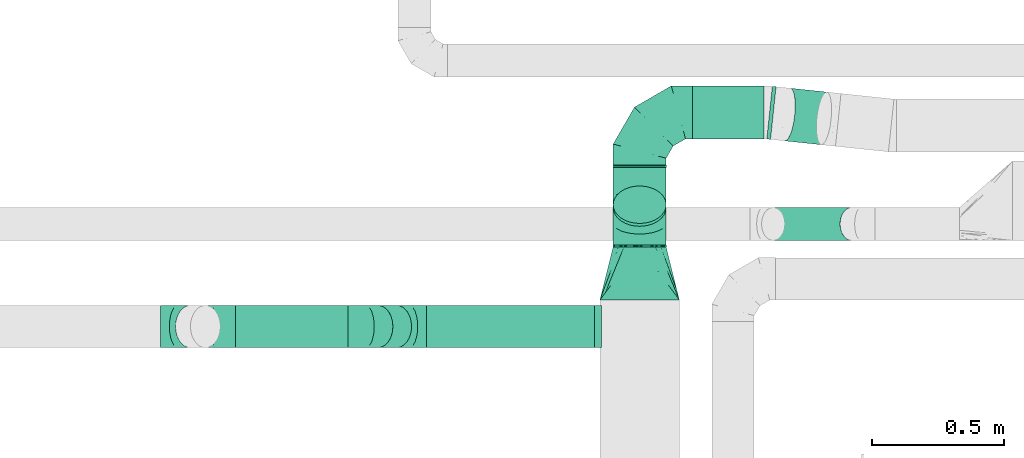
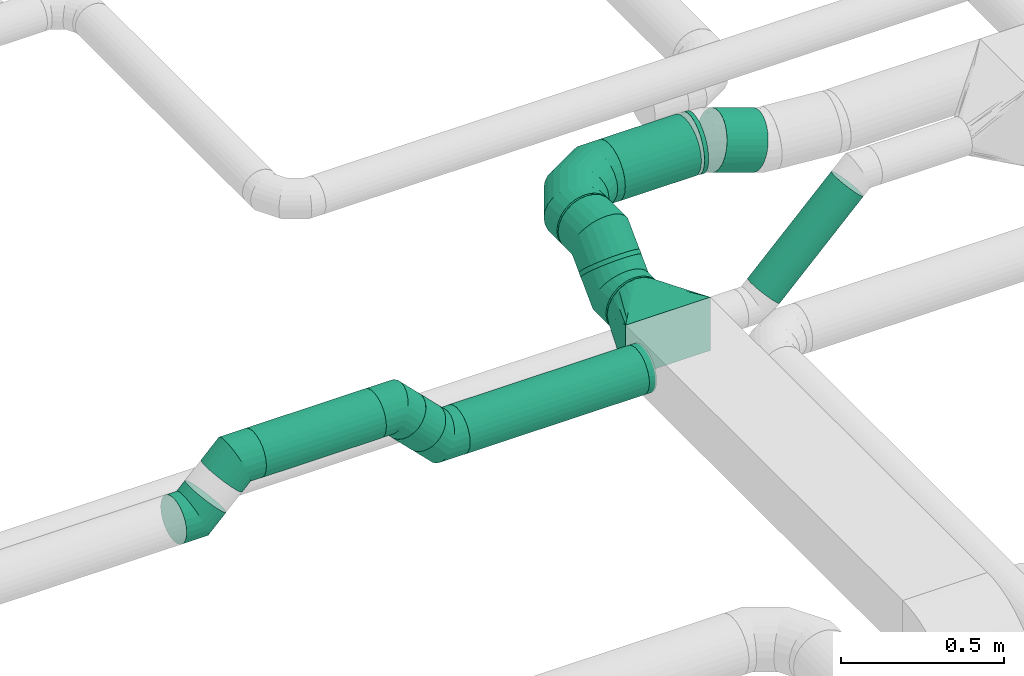
# One storey, part 10 of 60: 10 flow segments, 9 flow fittings.
"""IFC2X3 building model written with IfcOpenShell, lengths in millimetres."""

from ifc_helpers import new_model, entity, si_unit, converted_unit, derived_unit, direction, frame, origin, origin_2d_with_axis, place, context, subcontext, project, spatial, circle, extrude, faceted_brep, source, transform, mapped, material, type_object, type_shapes, element, save


model = new_model("IFC2X3")

# Units and contexts
model_context = context("Model", 3, precision=0.01, world=origin(), true_north=direction((6.12303176911189e-17, 1.0)))
body_context = subcontext(model_context, "Body", "Model", "MODEL_VIEW")
ifc_project = project(units=[si_unit("LENGTHUNIT", "METRE", prefix="MILLI"), si_unit("AREAUNIT", "SQUARE_METRE"), si_unit("VOLUMEUNIT", "CUBIC_METRE"), converted_unit("PLANEANGLEUNIT", "DEGREE", entity("IfcRatioMeasure", 0.0174532925199433), si_unit("PLANEANGLEUNIT", "RADIAN"), dimensions=[0, 0, 0, 0, 0, 0, 0]), si_unit("MASSUNIT", "GRAM", prefix="KILO"), derived_unit("MASSDENSITYUNIT", [(si_unit("MASSUNIT", "GRAM", prefix="KILO"), 1), (si_unit("LENGTHUNIT", "METRE"), -3)]), derived_unit("MOMENTOFINERTIAUNIT", [(si_unit("LENGTHUNIT", "METRE"), 4)]), si_unit("TIMEUNIT", "SECOND"), si_unit("FREQUENCYUNIT", "HERTZ"), si_unit("THERMODYNAMICTEMPERATUREUNIT", "DEGREE_CELSIUS"), derived_unit("THERMALTRANSMITTANCEUNIT", [(si_unit("MASSUNIT", "GRAM", prefix="KILO"), 1), (si_unit("THERMODYNAMICTEMPERATUREUNIT", "KELVIN"), -1), (si_unit("TIMEUNIT", "SECOND"), -3)]), derived_unit("VOLUMETRICFLOWRATEUNIT", [(si_unit("LENGTHUNIT", "METRE"), 3), (si_unit("TIMEUNIT", "SECOND"), -1)]), derived_unit("MASSFLOWRATEUNIT", [(si_unit("MASSUNIT", "GRAM", prefix="KILO"), 1), (si_unit("TIMEUNIT", "SECOND"), -1)]), derived_unit("ROTATIONALFREQUENCYUNIT", [(si_unit("TIMEUNIT", "SECOND"), -1)]), si_unit("ELECTRICCURRENTUNIT", "AMPERE"), si_unit("ELECTRICVOLTAGEUNIT", "VOLT"), si_unit("POWERUNIT", "WATT"), si_unit("FORCEUNIT", "NEWTON", prefix="KILO"), si_unit("ILLUMINANCEUNIT", "LUX"), si_unit("LUMINOUSFLUXUNIT", "LUMEN"), si_unit("LUMINOUSINTENSITYUNIT", "CANDELA"), derived_unit("USERDEFINED", [(si_unit("MASSUNIT", "GRAM", prefix="KILO"), -1), (si_unit("LENGTHUNIT", "METRE"), -2), (si_unit("TIMEUNIT", "SECOND"), 3), (si_unit("LUMINOUSFLUXUNIT", "LUMEN"), 1)]), derived_unit("LINEARVELOCITYUNIT", [(si_unit("LENGTHUNIT", "METRE"), 1), (si_unit("TIMEUNIT", "SECOND"), -1)]), si_unit("PRESSUREUNIT", "PASCAL"), derived_unit("USERDEFINED", [(si_unit("LENGTHUNIT", "METRE"), -2), (si_unit("MASSUNIT", "GRAM", prefix="KILO"), 1), (si_unit("TIMEUNIT", "SECOND"), -2)]), derived_unit("LINEARFORCEUNIT", [(si_unit("MASSUNIT", "GRAM", prefix="KILO"), 1), (si_unit("LENGTHUNIT", "METRE"), 1), (si_unit("TIMEUNIT", "SECOND"), -2), (si_unit("LENGTHUNIT", "METRE"), -1)]), derived_unit("PLANARFORCEUNIT", [(si_unit("MASSUNIT", "GRAM", prefix="KILO"), 1), (si_unit("LENGTHUNIT", "METRE"), 1), (si_unit("TIMEUNIT", "SECOND"), -2), (si_unit("LENGTHUNIT", "METRE"), -2)])], contexts=[model_context])

# Site, building, storey
site_placement = place(None, origin())
site = spatial("IfcSite", under=ifc_project, at=site_placement, CompositionType="ELEMENT")
building_placement = place(site_placement, origin())
building = spatial("IfcBuilding", under=site, at=building_placement, CompositionType="ELEMENT")
storey_placement = place(building_placement, frame((0.0, 0.0, 19800.0)))
storey = spatial("IfcBuildingStorey", under=building, at=storey_placement, CompositionType="ELEMENT", Elevation=19800.0)

# Flow segments
duct_segment_type = type_object("IfcDuctSegmentType", PredefinedType="NOTDEFINED")
flow_segment_1_placement = place(storey_placement, frame((17108.6, 9643.57, 3190.82)))
element("IfcFlowSegment", 1, at=flow_segment_1_placement, inside=storey, type_object=duct_segment_type, context=body_context, shape_type="SweptSolid", body=[
    extrude(circle(Radius=62.5, at=origin_2d_with_axis()), frame((45.79, 64.1, 45.79), z_axis=(0.707106781186546, 0.0, 0.707106781186549), x_axis=(0.0, -1.0, 0.0)), (0.0, 0.0, 1.0), 419.597442273526),
])
flow_segment_2_placement = place(storey_placement, frame((15845.68, 9238.83, 3329.22)))
element("IfcFlowSegment", 2, at=flow_segment_2_placement, inside=storey, type_object=duct_segment_type, context=body_context, shape_type="SweptSolid", body=[
    extrude(circle(Radius=80.0, at=origin_2d_with_axis()), frame((0.0, 81.6, 81.6), z_axis=(1.0, 0.0, 0.0), x_axis=(0.0, 1.0, 0.0)), (0.0, 0.0, 1.0), 634.545258658028),
])
flow_segment_3_placement = place(storey_placement, frame((15603.92, 9238.83, 3399.52)))
element("IfcFlowSegment", 3, at=flow_segment_3_placement, inside=storey, type_object=duct_segment_type, context=body_context, shape_type="SweptSolid", body=[
    extrude(circle(Radius=80.0, at=origin_2d_with_axis()), frame((128.62, 81.6, 58.16), z_axis=(-0.707106781186548, 0.0, 0.707106781186548), x_axis=(0.0, 1.0, 0.0)), (0.0, 0.0, 1.0), 99.6380507391843),
])
flow_segment_4_placement = place(storey_placement, frame((15124.2, 9238.83, 3493.4)))
element("IfcFlowSegment", 4, at=flow_segment_4_placement, inside=storey, type_object=duct_segment_type, context=body_context, shape_type="SweptSolid", body=[
    extrude(circle(Radius=80.0, at=origin_2d_with_axis()), frame((0.0, 81.6, 81.6), z_axis=(1.0, 0.0, 0.0), x_axis=(0.0, -1.0, 0.0)), (0.0, 0.0, 1.0), 424.742700306187),
])
flow_segment_5_placement = place(storey_placement, frame((16548.63, 9620.89, 3309.22)))
element("IfcFlowSegment", 5, at=flow_segment_5_placement, inside=storey, type_object=duct_segment_type, context=body_context, shape_type="SweptSolid", body=[
    extrude(circle(Radius=100.0, at=origin_2d_with_axis()), frame((101.6, 0.0, 101.6), z_axis=(0.0, 1.0, 0.0), x_axis=(1.0, 0.0, 0.0)), (0.0, 0.0, 1.0), 7.15728752538724),
])
flow_segment_6_placement = place(storey_placement, frame((16548.63, 9697.16, 3397.09)))
element("IfcFlowSegment", 6, at=flow_segment_6_placement, inside=storey, type_object=duct_segment_type, context=body_context, shape_type="SweptSolid", body=[
    extrude(circle(Radius=100.0, at=origin_2d_with_axis()), frame((101.6, 72.31, 72.31), z_axis=(0.0, 0.707106781186544, 0.707106781186551), x_axis=(1.0, 0.0, 0.0)), (0.0, 0.0, 1.0), 15.3196256846732),
])
flow_segment_7_placement = place(storey_placement, frame((16548.63, 9921.72, 3437.21)))
element("IfcFlowSegment", 7, at=flow_segment_7_placement, inside=storey, type_object=duct_segment_type, context=body_context, shape_type="SweptSolid", body=[
    extrude(circle(Radius=100.0, at=origin_2d_with_axis()), frame((101.6, 0.0, 101.6), z_axis=(0.0, 1.0, 0.0), x_axis=(1.0, 0.0, 0.0)), (0.0, 0.0, 1.0), 7.15728752537642),
])
flow_segment_8_placement = place(storey_placement, frame((16850.22, 10027.28, 3437.21)))
element("IfcFlowSegment", 8, at=flow_segment_8_placement, inside=storey, type_object=duct_segment_type, context=body_context, shape_type="SweptSolid", body=[
    extrude(circle(Radius=100.0, at=origin_2d_with_axis()), frame((0.0, 101.6, 101.6), z_axis=(1.0, 0.0, 0.0), x_axis=(0.0, -1.0, 0.0)), (0.0, 0.0, 1.0), 269.513342872284),
])
flow_segment_9_placement = place(storey_placement, frame((17128.6, 10025.25, 3437.21)))
element("IfcFlowSegment", 9, at=flow_segment_9_placement, inside=storey, type_object=duct_segment_type, context=body_context, shape_type="SweptSolid", body=[
    extrude(circle(Radius=100.0, at=origin_2d_with_axis()), frame((26.13, 101.05, 101.6), z_axis=(-0.994516576413548, 0.104579057361771, 0.0), x_axis=(0.104579057361771, 0.994516576413548, 0.0)), (0.0, 0.0, 1.0), 14.1587164881459),
])
flow_segment_10_placement = place(storey_placement, frame((17178.27, 10005.13, 3394.6)))
element("IfcFlowSegment", 10, at=flow_segment_10_placement, inside=storey, type_object=duct_segment_type, context=body_context, shape_type="SweptSolid", body=[
    extrude(circle(Radius=100.0, at=origin_2d_with_axis()), frame((167.81, 101.05, 97.86), z_axis=(-0.957389353768833, 0.100674919373033, 0.270684661366933), x_axis=(0.104579057362016, 0.994516576413522, 0.0)), (0.0, 0.0, 1.0), 143.623017739295),
])

# Flow fittings
ifc_material = material()
duct_fitting_type_1 = type_object("IfcDuctFittingType", PredefinedType="NOTDEFINED", material=ifc_material)
shared_shape_1 = source(origin(), body_context, "Body", "Brep", [
    faceted_brep([(-200.0, 0.0, -100.0), (-200.0, -25.88, -96.59), (-200.0, -50.0, -86.6), (-200.0, -70.71, -70.71), (-200.0, -86.6, -50.0), (-200.0, -96.59, -25.88), (-200.0, -100.0, 0.0), (-200.0, -96.59, 25.88), (-200.0, -86.6, 50.0), (-200.0, -70.71, 70.71), (-200.0, -50.0, 86.6), (-200.0, -25.88, 96.59), (-200.0, 0.0, 100.0), (-200.0, 25.88, 96.59), (-200.0, 50.0, 86.6), (-200.0, 70.71, 70.71), (-200.0, 86.6, 50.0), (-200.0, 96.59, 25.88), (-200.0, 100.0, 0.0), (-200.0, 96.59, -25.88), (-200.0, 86.6, -50.0), (-200.0, 70.71, -70.71), (-200.0, 50.0, -86.6), (-200.0, 25.88, -96.59), (-153.35, 25.88, 96.59), (-159.81, 50.0, 86.6), (-146.41, 0.0, 100.0), (-165.36, 70.71, 70.71), (-172.29, 96.59, 25.88), (-173.21, 100.0, 0.0), (-169.62, 86.6, 50.0), (-169.62, 86.6, -50.0), (-165.36, 70.71, -70.71), (-172.29, 96.59, -25.88), (-153.35, 25.88, -96.59), (-146.41, 0.0, -100.0), (-159.81, 50.0, -86.6), (-139.48, -25.88, -96.59), (-133.01, -50.0, -86.6), (-127.46, -70.71, -70.71), (-123.21, -86.6, -50.0), (-120.53, -96.59, -25.88), (-119.62, -100.0, 0.0), (-120.53, -96.59, 25.88), (-123.21, -86.6, 50.0), (-127.46, -70.71, 70.71), (-133.01, -50.0, 86.6), (-139.48, -25.88, 96.59), (-72.54, 72.54, 96.59), (-90.19, 90.19, 86.6), (-53.59, 53.59, 100.0), (-105.35, 105.35, 70.71), (-116.99, 116.99, 50.0), (-124.3, 124.3, 25.88), (-126.79, 126.79, 0.0), (-124.3, 124.3, -25.88), (-116.99, 116.99, -50.0), (-105.35, 105.35, -70.71), (-72.54, 72.54, -96.59), (-53.59, 53.59, -100.0), (-90.19, 90.19, -86.6), (-34.64, 34.64, -96.59), (-16.99, 16.99, -86.6), (-1.83, 1.83, -70.71), (9.81, -9.81, -50.0), (17.12, -17.12, -25.88), (19.62, -19.62, 0.0), (17.12, -17.12, 25.88), (9.81, -9.81, 50.0), (-1.83, 1.83, 70.71), (-16.99, 16.99, 86.6), (-34.64, 34.64, 96.59), (-25.88, 153.35, 96.59), (-50.0, 159.81, 86.6), (0.0, 146.41, 100.0), (-70.71, 165.36, 70.71), (-86.6, 169.62, 50.0), (-96.59, 172.29, 25.88), (-100.0, 173.21, 0.0), (-96.59, 172.29, -25.88), (-86.6, 169.62, -50.0), (-70.71, 165.36, -70.71), (-25.88, 153.35, -96.59), (0.0, 146.41, -100.0), (-50.0, 159.81, -86.6), (25.88, 139.48, -96.59), (50.0, 133.01, -86.6), (70.71, 127.46, -70.71), (86.6, 123.21, -50.0), (96.59, 120.53, -25.88), (100.0, 119.62, 0.0), (96.59, 120.53, 25.88), (86.6, 123.21, 50.0), (70.71, 127.46, 70.71), (50.0, 133.01, 86.6), (25.88, 139.48, 96.59), (-25.88, 200.0, -96.59), (-50.0, 200.0, -86.6), (-70.71, 200.0, -70.71), (-86.6, 200.0, -50.0), (-96.59, 200.0, -25.88), (-100.0, 200.0, 0.0), (-96.59, 200.0, 25.88), (-86.6, 200.0, 50.0), (-70.71, 200.0, 70.71), (-50.0, 200.0, 86.6), (-25.88, 200.0, 96.59), (0.0, 200.0, 100.0), (25.88, 200.0, 96.59), (50.0, 200.0, 86.6), (70.71, 200.0, 70.71), (86.6, 200.0, 50.0), (96.59, 200.0, 25.88), (100.0, 200.0, 0.0), (96.59, 200.0, -25.88), (86.6, 200.0, -50.0), (70.71, 200.0, -70.71), (50.0, 200.0, -86.6), (25.88, 200.0, -96.59), (0.0, 200.0, -100.0)], [[[0, 1, 2, 3, 4, 5, 6, 7, 8, 9, 10, 11, 12, 13, 14, 15, 16, 17, 18, 19, 20, 21, 22, 23]], [[24, 25, 14, 13]], [[26, 24, 13, 12]], [[14, 25, 27, 15]], [[28, 29, 18, 17]], [[30, 28, 17, 16]], [[15, 27, 30, 16]], [[20, 31, 32, 21]], [[33, 31, 20, 19]], [[18, 29, 33, 19]], [[34, 35, 0, 23]], [[36, 34, 23, 22]], [[32, 36, 22, 21]], [[1, 0, 35, 37]], [[2, 1, 37, 38]], [[38, 39, 3, 2]], [[5, 4, 40, 41]], [[6, 5, 41, 42]], [[39, 40, 4, 3]], [[6, 42, 43, 7]], [[7, 43, 44, 8]], [[8, 44, 45, 9]], [[9, 45, 46, 10]], [[10, 46, 47, 11]], [[26, 12, 11, 47]], [[48, 49, 25, 24]], [[50, 48, 24, 26]], [[27, 25, 49, 51]], [[52, 53, 28, 30]], [[51, 52, 30, 27]], [[29, 28, 53, 54]], [[55, 56, 31, 33]], [[54, 55, 33, 29]], [[32, 31, 56, 57]], [[58, 59, 35, 34]], [[60, 58, 34, 36]], [[57, 60, 36, 32]], [[37, 35, 59, 61]], [[38, 37, 61, 62]], [[39, 38, 62, 63]], [[41, 40, 64, 65]], [[42, 41, 65, 66]], [[63, 64, 40, 39]], [[43, 42, 66, 67]], [[44, 43, 67, 68]], [[68, 69, 45, 44]], [[46, 45, 69, 70]], [[47, 46, 70, 71]], [[26, 47, 71, 50]], [[72, 73, 49, 48]], [[74, 72, 48, 50]], [[51, 49, 73, 75]], [[76, 77, 53, 52]], [[75, 76, 52, 51]], [[54, 53, 77, 78]], [[79, 80, 56, 55]], [[78, 79, 55, 54]], [[57, 56, 80, 81]], [[82, 83, 59, 58]], [[84, 82, 58, 60]], [[81, 84, 60, 57]], [[61, 59, 83, 85]], [[62, 61, 85, 86]], [[63, 62, 86, 87]], [[65, 64, 88, 89]], [[66, 65, 89, 90]], [[87, 88, 64, 63]], [[67, 66, 90, 91]], [[68, 67, 91, 92]], [[92, 93, 69, 68]], [[70, 69, 93, 94]], [[71, 70, 94, 95]], [[50, 71, 95, 74]], [[96, 97, 98, 99, 100, 101, 102, 103, 104, 105, 106, 107, 108, 109, 110, 111, 112, 113, 114, 115, 116, 117, 118, 119]], [[72, 74, 107, 106]], [[73, 72, 106, 105]], [[75, 73, 105, 104]], [[102, 101, 78, 77]], [[103, 102, 77, 76]], [[75, 104, 103, 76]], [[78, 101, 100, 79]], [[79, 100, 99, 80]], [[80, 99, 98, 81]], [[84, 97, 96, 82]], [[82, 96, 119, 83]], [[84, 81, 98, 97]], [[118, 117, 86, 85]], [[119, 118, 85, 83]], [[116, 87, 86, 117]], [[88, 115, 114, 89]], [[89, 114, 113, 90]], [[115, 88, 87, 116]], [[91, 90, 113, 112]], [[92, 91, 112, 111]], [[111, 110, 93, 92]], [[95, 94, 109, 108]], [[74, 95, 108, 107]], [[110, 109, 94, 93]]]),
])
type_shapes(duct_fitting_type_1, [shared_shape_1])
flow_fitting_1_placement = place(storey_placement, frame((16650.22, 10128.88, 3538.81), z_axis=(0.0, 0.0, 1.0), x_axis=(-1.0, 0.0, 0.0)))
element("IfcFlowFitting", 11, at=flow_fitting_1_placement, inside=storey, type_object=duct_fitting_type_1, material=ifc_material, context=body_context, shape_type="MappedRepresentation", body=[
    mapped(shared_shape_1, transform((0.0, 0.0, 0.0), scale=1.0)),
])
duct_fitting_type_2 = type_object("IfcDuctFittingType", PredefinedType="NOTDEFINED", material=ifc_material)
shared_shape_2 = source(origin(), body_context, "Body", "Brep", [
    faceted_brep([(-66.27, 0.0, -80.0), (-66.27, -20.71, -77.27), (-66.27, -40.0, -69.28), (-66.27, -56.57, -56.57), (-66.27, -69.28, -40.0), (-66.27, -77.27, -20.71), (-66.27, -80.0, 0.0), (-66.27, -77.27, 20.71), (-66.27, -69.28, 40.0), (-66.27, -56.57, 56.57), (-66.27, -40.0, 69.28), (-66.27, -20.71, 77.27), (-66.27, 0.0, 80.0), (-66.27, 20.71, 77.27), (-66.27, 40.0, 69.28), (-66.27, 56.57, 56.57), (-66.27, 69.28, 40.0), (-66.27, 77.27, 20.71), (-66.27, 80.0, 0.0), (-66.27, 77.27, -20.71), (-66.27, 69.28, -40.0), (-66.27, 56.57, -56.57), (-66.27, 40.0, -69.28), (-66.27, 20.71, -77.27), (-8.58, 20.71, 77.27), (-16.57, 40.0, 69.28), (0.0, 0.0, 80.0), (-23.43, 56.57, 56.57), (-28.7, 69.28, 40.0), (-32.01, 77.27, 20.71), (-33.14, 80.0, 0.0), (-32.01, 77.27, -20.71), (-28.7, 69.28, -40.0), (-23.43, 56.57, -56.57), (-8.58, 20.71, -77.27), (0.0, 0.0, -80.0), (-16.57, 40.0, -69.28), (8.58, -20.71, -77.27), (16.57, -40.0, -69.28), (23.43, -56.57, -56.57), (28.7, -69.28, -40.0), (32.01, -77.27, -20.71), (33.14, -80.0, 0.0), (32.01, -77.27, 20.71), (28.7, -69.28, 40.0), (23.43, -56.57, 56.57), (16.57, -40.0, 69.28), (8.58, -20.71, 77.27), (46.86, 46.86, 80.0), (32.22, 61.5, 77.27), (18.58, 75.15, 69.28), (6.86, 86.86, 56.57), (-2.13, 95.85, 40.0), (-7.78, 101.5, 20.71), (-9.71, 103.43, 0.0), (-7.78, 101.5, -20.71), (-2.13, 95.85, -40.0), (6.86, 86.86, -56.57), (18.58, 75.15, -69.28), (32.22, 61.5, -77.27), (46.86, 46.86, -80.0), (61.5, 32.22, -77.27), (75.15, 18.58, -69.28), (86.86, 6.86, -56.57), (95.85, -2.13, -40.0), (101.5, -7.78, -20.71), (103.43, -9.71, 0.0), (101.5, -7.78, 20.71), (95.85, -2.13, 40.0), (86.86, 6.86, 56.57), (75.15, 18.58, 69.28), (61.5, 32.22, 77.27)], [[[0, 1, 2, 3, 4, 5, 6, 7, 8, 9, 10, 11, 12, 13, 14, 15, 16, 17, 18, 19, 20, 21, 22, 23]], [[24, 25, 14, 13]], [[26, 24, 13, 12]], [[14, 25, 27, 15]], [[28, 29, 17, 16]], [[28, 16, 15, 27]], [[30, 18, 17, 29]], [[31, 32, 20, 19]], [[30, 31, 19, 18]], [[32, 33, 21, 20]], [[34, 35, 0, 23]], [[36, 34, 23, 22]], [[33, 36, 22, 21]], [[1, 0, 35, 37]], [[2, 1, 37, 38]], [[38, 39, 3, 2]], [[5, 4, 40, 41]], [[6, 5, 41, 42]], [[39, 40, 4, 3]], [[6, 42, 43, 7]], [[7, 43, 44, 8]], [[8, 44, 45, 9]], [[9, 45, 46, 10]], [[10, 46, 47, 11]], [[26, 12, 11, 47]], [[24, 26, 48, 49]], [[25, 24, 49, 50]], [[27, 25, 50, 51]], [[29, 28, 52, 53]], [[30, 29, 53, 54]], [[51, 52, 28, 27]], [[30, 54, 55, 31]], [[31, 55, 56, 32]], [[57, 33, 32, 56]], [[36, 58, 59, 34]], [[34, 59, 60, 35]], [[58, 36, 33, 57]], [[35, 60, 61, 37]], [[37, 61, 62, 38]], [[63, 39, 38, 62]], [[40, 64, 65, 41]], [[41, 65, 66, 42]], [[64, 40, 39, 63]], [[43, 42, 66, 67]], [[44, 43, 67, 68]], [[68, 69, 45, 44]], [[47, 46, 70, 71]], [[26, 47, 71, 48]], [[69, 70, 46, 45]], [[59, 58, 57, 56, 55, 54, 53, 52, 51, 50, 49, 48, 71, 70, 69, 68, 67, 66, 65, 64, 63, 62, 61, 60]]]),
])
type_shapes(duct_fitting_type_2, [shared_shape_2])
for number, where, z_axis, x_axis in (
    (12, (14907.93, 9320.42, 3425.0), (0.0, -1.0, 0.0), (1.0, 0.0, 0.0)),
    (13, (15057.93, 9320.42, 3575.0), (0.0, 1.0, 0.0), (0.707106781186425, 0.0, 0.70710678118667)),
    (14, (15779.4, 9320.42, 3410.82), (0.0, 1.0, 0.0), (-1.0, 0.0, 0.0)),
    (15, (15615.22, 9320.42, 3575.0), (0.0, -1.0, 0.0), (-0.707106781186425, 0.0, 0.70710678118667)),
):
    element("IfcFlowFitting", number, at=place(storey_placement, frame(where, z_axis=z_axis, x_axis=x_axis)), inside=storey, type_object=duct_fitting_type_2, material=ifc_material, context=body_context, shape_type="MappedRepresentation", body=[
        mapped(shared_shape_2, transform((0.0, 0.0, 0.0), scale=1.0)),
    ])
duct_fitting_type_3 = type_object("IfcDuctFittingType", PredefinedType="NOTDEFINED", material=ifc_material)
shared_shape_3 = source(origin(), body_context, "Body", "Brep", [
    faceted_brep([(-82.84, 0.0, -100.0), (-82.84, -25.88, -96.59), (-82.84, -50.0, -86.6), (-82.84, -70.71, -70.71), (-82.84, -86.6, -50.0), (-82.84, -96.59, -25.88), (-82.84, -100.0, 0.0), (-82.84, -96.59, 25.88), (-82.84, -86.6, 50.0), (-82.84, -70.71, 70.71), (-82.84, -50.0, 86.6), (-82.84, -25.88, 96.59), (-82.84, 0.0, 100.0), (-82.84, 25.88, 96.59), (-82.84, 50.0, 86.6), (-82.84, 70.71, 70.71), (-82.84, 86.6, 50.0), (-82.84, 96.59, 25.88), (-82.84, 100.0, 0.0), (-82.84, 96.59, -25.88), (-82.84, 86.6, -50.0), (-82.84, 70.71, -70.71), (-82.84, 50.0, -86.6), (-82.84, 25.88, -96.59), (-10.72, 25.88, 96.59), (-20.71, 50.0, 86.6), (0.0, 0.0, 100.0), (-29.29, 70.71, 70.71), (-35.87, 86.6, 50.0), (-40.01, 96.59, 25.88), (-41.42, 100.0, 0.0), (-40.01, 96.59, -25.88), (-35.87, 86.6, -50.0), (-29.29, 70.71, -70.71), (-10.72, 25.88, -96.59), (0.0, 0.0, -100.0), (-20.71, 50.0, -86.6), (10.72, -25.88, -96.59), (20.71, -50.0, -86.6), (29.29, -70.71, -70.71), (35.87, -86.6, -50.0), (40.01, -96.59, -25.88), (41.42, -100.0, 0.0), (40.01, -96.59, 25.88), (35.87, -86.6, 50.0), (29.29, -70.71, 70.71), (20.71, -50.0, 86.6), (10.72, -25.88, 96.59), (58.58, 58.58, 100.0), (40.28, 76.88, 96.59), (23.22, 93.93, 86.6), (8.58, 108.58, 70.71), (-2.66, 119.82, 50.0), (-9.72, 126.88, 25.88), (-12.13, 129.29, 0.0), (-9.72, 126.88, -25.88), (-2.66, 119.82, -50.0), (8.58, 108.58, -70.71), (23.22, 93.93, -86.6), (40.28, 76.88, -96.59), (58.58, 58.58, -100.0), (76.88, 40.28, -96.59), (93.93, 23.22, -86.6), (108.58, 8.58, -70.71), (119.82, -2.66, -50.0), (126.88, -9.72, -25.88), (129.29, -12.13, 0.0), (126.88, -9.72, 25.88), (119.82, -2.66, 50.0), (108.58, 8.58, 70.71), (93.93, 23.22, 86.6), (76.88, 40.28, 96.59)], [[[0, 1, 2, 3, 4, 5, 6, 7, 8, 9, 10, 11, 12, 13, 14, 15, 16, 17, 18, 19, 20, 21, 22, 23]], [[24, 25, 14, 13]], [[26, 24, 13, 12]], [[14, 25, 27, 15]], [[28, 29, 17, 16]], [[28, 16, 15, 27]], [[30, 18, 17, 29]], [[31, 32, 20, 19]], [[30, 31, 19, 18]], [[32, 33, 21, 20]], [[34, 35, 0, 23]], [[36, 34, 23, 22]], [[33, 36, 22, 21]], [[1, 0, 35, 37]], [[2, 1, 37, 38]], [[38, 39, 3, 2]], [[5, 4, 40, 41]], [[6, 5, 41, 42]], [[39, 40, 4, 3]], [[6, 42, 43, 7]], [[7, 43, 44, 8]], [[8, 44, 45, 9]], [[9, 45, 46, 10]], [[10, 46, 47, 11]], [[26, 12, 11, 47]], [[24, 26, 48, 49]], [[25, 24, 49, 50]], [[27, 25, 50, 51]], [[29, 28, 52, 53]], [[30, 29, 53, 54]], [[51, 52, 28, 27]], [[30, 54, 55, 31]], [[31, 55, 56, 32]], [[57, 33, 32, 56]], [[36, 58, 59, 34]], [[34, 59, 60, 35]], [[58, 36, 33, 57]], [[35, 60, 61, 37]], [[37, 61, 62, 38]], [[63, 39, 38, 62]], [[40, 64, 65, 41]], [[41, 65, 66, 42]], [[64, 40, 39, 63]], [[43, 42, 66, 67]], [[44, 43, 67, 68]], [[68, 69, 45, 44]], [[47, 46, 70, 71]], [[26, 47, 71, 48]], [[69, 70, 46, 45]], [[59, 58, 57, 56, 55, 54, 53, 52, 51, 50, 49, 48, 71, 70, 69, 68, 67, 66, 65, 64, 63, 62, 61, 60]]]),
])
type_shapes(duct_fitting_type_3, [shared_shape_3])
for number, where, z_axis, x_axis in (
    (16, (16650.22, 9710.89, 3410.82), (1.0, 0.0, 0.0), (0.0, 1.0, 0.0)),
    (17, (16650.22, 9838.88, 3538.81), (-1.0, 0.0, 0.0), (0.0, 0.707106781186509, 0.707106781186586)),
):
    element("IfcFlowFitting", number, at=place(storey_placement, frame(where, z_axis=z_axis, x_axis=x_axis)), inside=storey, type_object=duct_fitting_type_3, material=ifc_material, context=body_context, shape_type="MappedRepresentation", body=[
        mapped(shared_shape_3, transform((0.0, 0.0, 0.0), scale=1.0)),
    ])
duct_fitting_type_4 = type_object("IfcDuctFittingType", PredefinedType="NOTDEFINED", material=ifc_material)
shared_shape_4 = source(origin(), body_context, "Body", "Brep", [
    faceted_brep([(20.0, 20.71, -77.27), (20.0, 40.0, -69.28), (20.0, 56.57, -56.57), (20.0, 69.28, -40.0), (20.0, 77.27, -20.71), (20.0, 80.0, 0.0), (20.0, 77.27, 20.71), (20.0, 69.28, 40.0), (20.0, 56.57, 56.57), (20.0, 40.0, 69.28), (20.0, 20.71, 77.27), (20.0, 0.0, 80.0), (20.0, -20.71, 77.27), (20.0, -40.0, 69.28), (20.0, -56.57, 56.57), (20.0, -69.28, 40.0), (20.0, -77.27, 20.71), (20.0, -80.0, 0.0), (20.0, -77.27, -20.71), (20.0, -69.28, -40.0), (20.0, -56.57, -56.57), (20.0, -40.0, -69.28), (20.0, -20.71, -77.27), (20.0, 0.0, -80.0), (0.0, 0.0, 80.0), (0.0, 20.71, 77.27), (-6.1, 20.71, 77.27), (-6.1, 0.0, 80.0), (0.0, 40.0, 69.28), (-6.1, 40.0, 69.28), (0.0, 56.57, 56.57), (-6.1, 56.57, 56.57), (0.0, 69.28, 40.0), (0.0, 77.27, 20.71), (-6.1, 77.27, 20.71), (-6.1, 69.28, 40.0), (0.0, 80.0, 0.0), (-6.1, 80.0, 0.0), (0.0, 77.27, -20.71), (-6.1, 77.27, -20.71), (0.0, 69.28, -40.0), (-6.1, 69.28, -40.0), (0.0, 56.57, -56.57), (-6.1, 56.57, -56.57), (0.0, 40.0, -69.28), (0.0, 20.71, -77.27), (-6.1, 20.71, -77.27), (-6.1, 40.0, -69.28), (0.0, 0.0, -80.0), (-6.1, 0.0, -80.0), (0.0, -20.71, -77.27), (-6.1, -20.71, -77.27), (0.0, -40.0, -69.28), (-6.1, -40.0, -69.28), (0.0, -56.57, -56.57), (-6.1, -56.57, -56.57), (0.0, -69.28, -40.0), (0.0, -77.27, -20.71), (-6.1, -77.27, -20.71), (-6.1, -69.28, -40.0), (0.0, -80.0, 0.0), (-6.1, -80.0, 0.0), (0.0, -77.27, 20.71), (-6.1, -77.27, 20.71), (0.0, -69.28, 40.0), (-6.1, -69.28, 40.0), (0.0, -56.57, 56.57), (-6.1, -56.57, 56.57), (0.0, -40.0, 69.28), (0.0, -20.71, 77.27), (-6.1, -20.71, 77.27), (-6.1, -40.0, 69.28)], [[[0, 1, 2, 3, 4, 5, 6, 7, 8, 9, 10, 11, 12, 13, 14, 15, 16, 17, 18, 19, 20, 21, 22, 23]], [[24, 11, 10, 25, 26, 27]], [[25, 10, 9, 28, 29, 26]], [[28, 9, 8, 30, 31, 29]], [[32, 7, 6, 33, 34, 35]], [[33, 6, 5, 36, 37, 34]], [[30, 8, 7, 32, 35, 31]], [[36, 5, 4, 38, 39, 37]], [[38, 4, 3, 40, 41, 39]], [[40, 3, 2, 42, 43, 41]], [[44, 1, 0, 45, 46, 47]], [[45, 0, 23, 48, 49, 46]], [[42, 2, 1, 44, 47, 43]], [[48, 23, 22, 50, 51, 49]], [[50, 22, 21, 52, 53, 51]], [[52, 21, 20, 54, 55, 53]], [[56, 19, 18, 57, 58, 59]], [[57, 18, 17, 60, 61, 58]], [[54, 20, 19, 56, 59, 55]], [[60, 17, 16, 62, 63, 61]], [[62, 16, 15, 64, 65, 63]], [[64, 15, 14, 66, 67, 65]], [[68, 13, 12, 69, 70, 71]], [[69, 12, 11, 24, 27, 70]], [[66, 14, 13, 68, 71, 67]], [[49, 51, 53, 55, 59, 58, 61, 63, 65, 67, 71, 70, 27, 26, 29, 31, 35, 34, 37, 39, 41, 43, 47, 46]]]),
])
type_shapes(duct_fitting_type_4, [shared_shape_4])
flow_fitting_2_placement = place(storey_placement, frame((16500.22, 9320.42, 3410.82), z_axis=(0.0, 0.0, -1.0), x_axis=(-1.0, 0.0, 0.0)))
element("IfcFlowFitting", 18, at=flow_fitting_2_placement, inside=storey, type_object=duct_fitting_type_4, material=ifc_material, context=body_context, shape_type="MappedRepresentation", body=[
    mapped(shared_shape_4, transform((0.0, 0.0, 0.0), scale=1.0)),
])
duct_fitting_type_5 = type_object("IfcDuctFittingType", PredefinedType="NOTDEFINED", material=ifc_material)
shared_shape_5 = source(origin(), body_context, "Body", "Brep", [
    faceted_brep([(200.0, 30.9, 95.11), (200.0, 19.08, 96.98), (200.0, 9.54, 98.49), (200.0, 4.77, 99.24), (200.0, 0.0, 100.0), (200.0, -4.77, 99.24), (200.0, -9.54, 98.49), (200.0, -19.08, 96.98), (200.0, -30.9, 95.11), (200.0, -44.84, 88.0), (200.0, -58.78, 80.9), (200.0, -69.84, 69.84), (200.0, -80.9, 58.78), (200.0, -88.0, 44.84), (200.0, -95.11, 30.9), (200.0, -96.98, 19.08), (200.0, -98.49, 9.54), (200.0, -99.24, 4.77), (200.0, -100.0, 0.0), (200.0, -99.24, -4.77), (200.0, -98.49, -9.54), (200.0, -96.98, -19.08), (200.0, -95.11, -30.9), (200.0, -88.0, -44.84), (200.0, -80.9, -58.78), (200.0, -69.84, -69.84), (200.0, -58.78, -80.9), (200.0, -44.84, -88.0), (200.0, -30.9, -95.11), (200.0, -19.08, -96.98), (200.0, -9.54, -98.49), (200.0, -4.77, -99.24), (200.0, 0.0, -100.0), (200.0, 4.77, -99.24), (200.0, 9.54, -98.49), (200.0, 19.08, -96.98), (200.0, 30.9, -95.11), (200.0, 44.84, -88.0), (200.0, 58.78, -80.9), (200.0, 69.84, -69.84), (200.0, 80.9, -58.78), (200.0, 88.0, -44.84), (200.0, 95.11, -30.9), (200.0, 96.98, -19.08), (200.0, 98.49, -9.54), (200.0, 99.24, -4.77), (200.0, 100.0, 0.0), (200.0, 99.24, 4.77), (200.0, 98.49, 9.54), (200.0, 96.98, 19.08), (200.0, 95.11, 30.9), (200.0, 88.0, 44.84), (200.0, 80.9, 58.78), (200.0, 69.84, 69.84), (200.0, 58.78, 80.9), (200.0, 44.84, 88.0), (0.0, -150.0, 100.0), (0.0, 150.0, 100.0), (0.0, 150.0, -100.0), (0.0, -150.0, -100.0), (104.11, -71.91, 100.0), (100.0, -108.15, 87.43), (26.03, -130.48, 100.0), (78.09, -91.44, 100.0), (52.06, -110.96, 100.0), (188.01, -8.99, 100.0), (176.03, -17.98, 100.0), (152.06, -35.96, 100.0), (128.09, -53.94, 100.0), (52.06, -136.99, 73.97), (78.09, -130.48, 60.96), (104.11, -123.97, 47.94), (128.09, -117.98, 35.96), (152.06, -111.99, 23.97), (176.03, -105.99, 11.99), (188.01, -103.0, 5.99), (26.03, -143.49, 86.99), (26.03, -143.49, -86.99), (52.06, -136.99, -73.97), (78.09, -130.48, -60.96), (104.11, -123.97, -47.94), (128.09, -117.98, -35.96), (152.06, -111.99, -23.97), (176.03, -105.99, -11.99), (188.01, -103.0, -5.99), (100.0, -112.43, -83.15), (52.06, -110.96, -100.0), (78.09, -91.44, -100.0), (104.11, -71.91, -100.0), (128.09, -53.94, -100.0), (152.06, -35.96, -100.0), (176.03, -17.98, -100.0), (188.01, -8.99, -100.0), (26.03, -130.48, -100.0), (26.03, 130.48, -100.0), (52.06, 110.96, -100.0), (78.09, 91.44, -100.0), (104.11, 71.91, -100.0), (128.09, 53.94, -100.0), (152.06, 35.96, -100.0), (176.03, 17.98, -100.0), (188.01, 8.99, -100.0), (100.0, 108.15, -87.43), (52.06, 136.99, -73.97), (78.09, 130.48, -60.96), (104.11, 123.97, -47.94), (128.09, 117.98, -35.96), (152.06, 111.99, -23.97), (176.03, 105.99, -11.99), (188.01, 103.0, -5.99), (26.03, 143.49, -86.99), (26.03, 143.49, 86.99), (52.06, 136.99, 73.97), (78.09, 130.48, 60.96), (104.11, 123.97, 47.94), (128.09, 117.98, 35.96), (152.06, 111.99, 23.97), (176.03, 105.99, 11.99), (188.01, 103.0, 5.99), (100.0, 112.43, 83.15), (52.06, 110.96, 100.0), (78.09, 91.44, 100.0), (104.11, 71.91, 100.0), (128.09, 53.94, 100.0), (152.06, 35.96, 100.0), (176.03, 17.98, 100.0), (188.01, 8.99, 100.0), (26.03, 130.48, 100.0)], [[[0, 1, 2, 3, 4, 5, 6, 7, 8, 9, 10, 11, 12, 13, 14, 15, 16, 17, 18, 19, 20, 21, 22, 23, 24, 25, 26, 27, 28, 29, 30, 31, 32, 33, 34, 35, 36, 37, 38, 39, 40, 41, 42, 43, 44, 45, 46, 47, 48, 49, 50, 51, 52, 53, 54, 55]], [[56, 57, 58, 59]], [[60, 9, 8]], [[56, 61, 62]], [[9, 60, 63, 64]], [[65, 66, 67, 68, 60, 8, 7, 6, 5, 4]], [[62, 61, 10]], [[13, 69, 70, 71]], [[64, 10, 9]], [[14, 71, 72, 73, 74, 75, 18, 17, 16, 15]], [[12, 76, 69]], [[71, 14, 13]], [[61, 76, 11]], [[10, 64, 62]], [[76, 12, 11]], [[10, 61, 11]], [[61, 56, 76]], [[69, 13, 12]], [[75, 74, 73, 72, 71, 70, 69, 76, 56, 59, 77, 78, 79, 80, 81, 82, 83, 84, 18]], [[80, 23, 22]], [[59, 85, 77]], [[23, 80, 79, 78]], [[84, 83, 82, 81, 80, 22, 21, 20, 19, 18]], [[77, 85, 24]], [[27, 86, 87, 88]], [[78, 24, 23]], [[28, 88, 89, 90, 91, 92, 32, 31, 30, 29]], [[26, 93, 86]], [[88, 28, 27]], [[85, 93, 25]], [[24, 78, 77]], [[93, 26, 25]], [[24, 85, 25]], [[85, 59, 93]], [[86, 27, 26]], [[92, 91, 90, 89, 88, 87, 86, 93, 59, 58, 94, 95, 96, 97, 98, 99, 100, 101, 32]], [[97, 37, 36]], [[58, 102, 94]], [[37, 97, 96, 95]], [[101, 100, 99, 98, 97, 36, 35, 34, 33, 32]], [[94, 102, 38]], [[41, 103, 104, 105]], [[95, 38, 37]], [[42, 105, 106, 107, 108, 109, 46, 45, 44, 43]], [[40, 110, 103]], [[105, 42, 41]], [[102, 110, 39]], [[38, 95, 94]], [[110, 40, 39]], [[38, 102, 39]], [[102, 58, 110]], [[103, 41, 40]], [[58, 57, 111, 112, 113, 114, 115, 116, 117, 118, 46, 109, 108, 107, 106, 105, 104, 103, 110]], [[114, 51, 50]], [[57, 119, 111]], [[51, 114, 113, 112]], [[118, 117, 116, 115, 114, 50, 49, 48, 47, 46]], [[111, 119, 52]], [[55, 120, 121, 122]], [[112, 52, 51]], [[0, 122, 123, 124, 125, 126, 4, 3, 2, 1]], [[54, 127, 120]], [[122, 0, 55]], [[119, 127, 53]], [[52, 112, 111]], [[127, 54, 53]], [[52, 119, 53]], [[119, 57, 127]], [[120, 55, 54]], [[57, 56, 62, 64, 63, 60, 68, 67, 66, 65, 4, 126, 125, 124, 123, 122, 121, 120, 127]]]),
])
type_shapes(duct_fitting_type_5, [shared_shape_5])
flow_fitting_3_placement = place(storey_placement, frame((16650.22, 9420.89, 3410.82), z_axis=(0.0, 0.0, 1.0), x_axis=(0.0, 1.0, 0.0)))
element("IfcFlowFitting", 19, at=flow_fitting_3_placement, inside=storey, type_object=duct_fitting_type_5, material=ifc_material, context=body_context, shape_type="MappedRepresentation", body=[
    mapped(shared_shape_5, transform((0.0, 0.0, 0.0), scale=1.0)),
])

save(model, "model.ifc")
